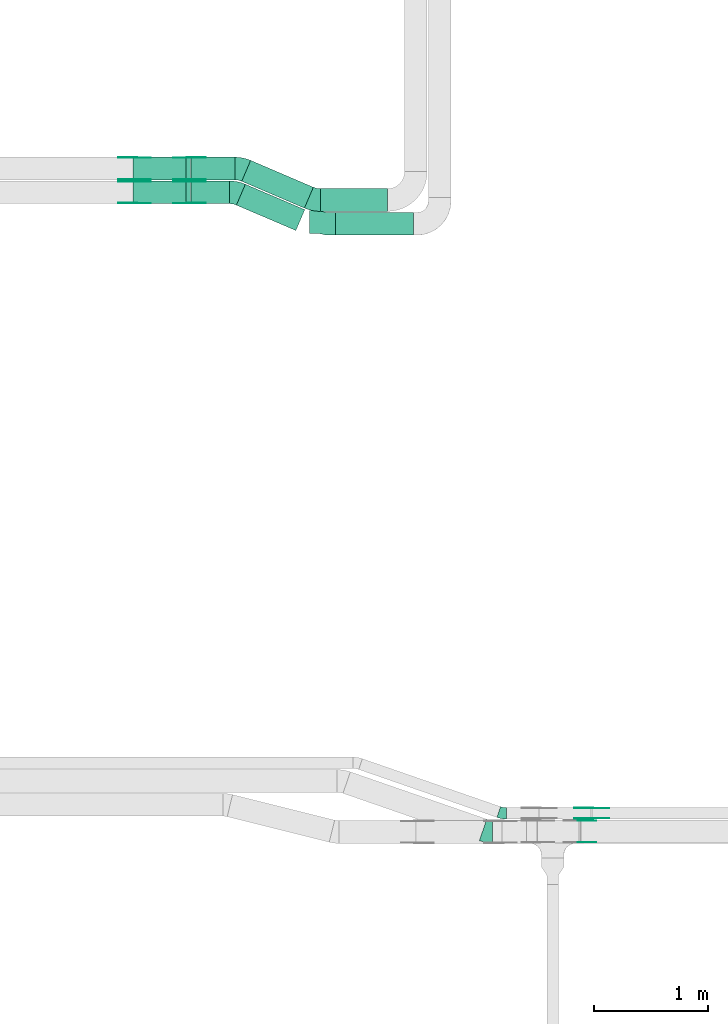
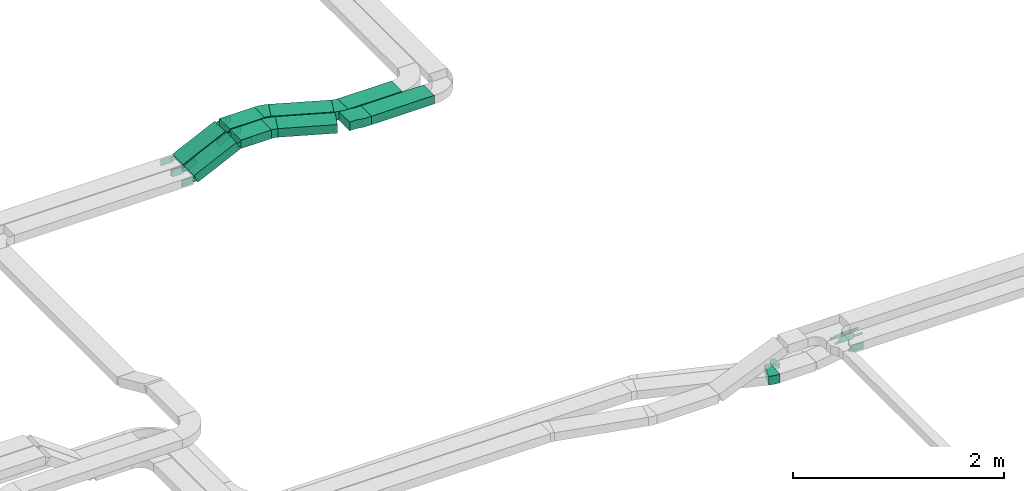
# One storey, part 15 of 25: 28 flow fittings, 8 flow segments.
"""IFC2X3 building model written with IfcOpenShell, lengths in millimetres."""

from ifc_helpers import new_model, entity, si_unit, converted_unit, derived_unit, direction, frame, frame_2d, origin, origin_2d_with_axis, place, context, subcontext, project, spatial, polyline, circle_curve, parameter, trimmed, segment, composite_curve, rectangle, outline, extrude, source, transform, mapped, material, type_object, type_shapes, element, save


model = new_model("IFC2X3")

# Units and contexts
model_context = context("Model", 3, precision=0.01, world=origin(), true_north=direction((6.12303176911189e-17, 1.0)))
body_context = subcontext(model_context, "Body", "Model", "MODEL_VIEW")
ifc_project = project(units=[si_unit("LENGTHUNIT", "METRE", prefix="MILLI"), si_unit("AREAUNIT", "SQUARE_METRE"), si_unit("VOLUMEUNIT", "CUBIC_METRE"), converted_unit("PLANEANGLEUNIT", "DEGREE", entity("IfcRatioMeasure", 0.0174532925199433), si_unit("PLANEANGLEUNIT", "RADIAN"), dimensions=[0, 0, 0, 0, 0, 0, 0]), si_unit("MASSUNIT", "GRAM", prefix="KILO"), derived_unit("MASSDENSITYUNIT", [(si_unit("MASSUNIT", "GRAM", prefix="KILO"), 1), (si_unit("LENGTHUNIT", "METRE"), -3)]), derived_unit("MOMENTOFINERTIAUNIT", [(si_unit("LENGTHUNIT", "METRE"), 4)]), si_unit("TIMEUNIT", "SECOND"), si_unit("FREQUENCYUNIT", "HERTZ"), si_unit("THERMODYNAMICTEMPERATUREUNIT", "DEGREE_CELSIUS"), derived_unit("THERMALTRANSMITTANCEUNIT", [(si_unit("MASSUNIT", "GRAM", prefix="KILO"), 1), (si_unit("THERMODYNAMICTEMPERATUREUNIT", "KELVIN"), -1), (si_unit("TIMEUNIT", "SECOND"), -3)]), derived_unit("VOLUMETRICFLOWRATEUNIT", [(si_unit("LENGTHUNIT", "METRE"), 3), (si_unit("TIMEUNIT", "SECOND"), -1)]), derived_unit("MASSFLOWRATEUNIT", [(si_unit("MASSUNIT", "GRAM", prefix="KILO"), 1), (si_unit("TIMEUNIT", "SECOND"), -1)]), derived_unit("ROTATIONALFREQUENCYUNIT", [(si_unit("TIMEUNIT", "SECOND"), -1)]), si_unit("ELECTRICCURRENTUNIT", "AMPERE"), si_unit("ELECTRICVOLTAGEUNIT", "VOLT"), si_unit("POWERUNIT", "WATT"), si_unit("FORCEUNIT", "NEWTON", prefix="KILO"), si_unit("ILLUMINANCEUNIT", "LUX"), si_unit("LUMINOUSFLUXUNIT", "LUMEN"), si_unit("LUMINOUSINTENSITYUNIT", "CANDELA"), derived_unit("USERDEFINED", [(si_unit("MASSUNIT", "GRAM", prefix="KILO"), -1), (si_unit("LENGTHUNIT", "METRE"), -2), (si_unit("TIMEUNIT", "SECOND"), 3), (si_unit("LUMINOUSFLUXUNIT", "LUMEN"), 1)]), derived_unit("LINEARVELOCITYUNIT", [(si_unit("LENGTHUNIT", "METRE"), 1), (si_unit("TIMEUNIT", "SECOND"), -1)]), si_unit("PRESSUREUNIT", "PASCAL"), derived_unit("USERDEFINED", [(si_unit("LENGTHUNIT", "METRE"), -2), (si_unit("MASSUNIT", "GRAM", prefix="KILO"), 1), (si_unit("TIMEUNIT", "SECOND"), -2)]), derived_unit("LINEARFORCEUNIT", [(si_unit("MASSUNIT", "GRAM", prefix="KILO"), 1), (si_unit("LENGTHUNIT", "METRE"), 1), (si_unit("TIMEUNIT", "SECOND"), -2), (si_unit("LENGTHUNIT", "METRE"), -1)]), derived_unit("PLANARFORCEUNIT", [(si_unit("MASSUNIT", "GRAM", prefix="KILO"), 1), (si_unit("LENGTHUNIT", "METRE"), 1), (si_unit("TIMEUNIT", "SECOND"), -2), (si_unit("LENGTHUNIT", "METRE"), -2)])], contexts=[model_context])

# Site, building, storey
site_placement = place(None, frame((0.0, -0.00077364408347762, 0.0)))
site = spatial("IfcSite", under=ifc_project, at=site_placement, CompositionType="ELEMENT")
building_placement = place(site_placement, origin())
building = spatial("IfcBuilding", under=site, at=building_placement, CompositionType="ELEMENT")
storey_placement = place(building_placement, frame((0.0, 0.0, 24000.0)))
storey = spatial("IfcBuildingStorey", under=building, at=storey_placement, CompositionType="ELEMENT", Elevation=24000.0)

# Flow segments
cable_carrier_segment_type = type_object("IfcCableCarrierSegmentType", PredefinedType="CABLETRAYSEGMENT")
flow_segment_1_placement = place(storey_placement, frame((39514.0995028436, 14090.3144759065, 2883.62105725889)))
element("IfcFlowSegment", 1, at=flow_segment_1_placement, inside=storey, type_object=cable_carrier_segment_type, context=body_context, shape_type="SweptSolid", body=[
    extrude(rectangle(XDim=686.50102542503, YDim=199.999999999998, at=frame_2d((-4.32009983342141e-12, 1.08002495835535e-12), x_axis=(1.0, 0.0))), frame((343.250512712511, 100.0, 0.0), z_axis=(0.0, 0.0, 1.0), x_axis=(-1.0, 0.0, 0.0)), (0.0, 0.0, 1.0), 100.000000000003),
])
flow_segment_2_placement = place(storey_placement, frame((39379.2280429504, 14300.3144759065, 2883.62105725893)))
element("IfcFlowSegment", 2, at=flow_segment_2_placement, inside=storey, type_object=cable_carrier_segment_type, context=body_context, shape_type="SweptSolid", body=[
    extrude(rectangle(XDim=590.372485318248, YDim=199.999999999998, at=frame_2d((0.0, 1.08002495835535e-12), x_axis=(1.0, 0.0))), frame((295.186242659133, 100.0, 0.0), z_axis=(0.0, 0.0, 1.0), x_axis=(-1.0, 0.0, 0.0)), (0.0, 0.0, 1.0), 100.000000000003),
])
flow_segment_3_placement = place(storey_placement, frame((38242.0489672401, 14367.8235638229, 2883.62105725891)))
element("IfcFlowSegment", 3, at=flow_segment_3_placement, inside=storey, type_object=cable_carrier_segment_type, context=body_context, shape_type="SweptSolid", body=[
    extrude(rectangle(XDim=337.638555069506, YDim=199.999999999998, at=origin_2d_with_axis()), frame((168.819277534753, 100.0, 0.0), z_axis=(0.0, 0.0, 1.0), x_axis=(-1.0, 0.0, 0.0)), (0.0, 0.0, 1.0), 100.000000000003),
])
flow_segment_4_placement = place(storey_placement, frame((38242.0489672412, 14577.8235638229, 2883.62105725665)))
element("IfcFlowSegment", 4, at=flow_segment_4_placement, inside=storey, type_object=cable_carrier_segment_type, context=body_context, shape_type="SweptSolid", body=[
    extrude(rectangle(XDim=384.036141225792, YDim=199.999999999998, at=origin_2d_with_axis()), frame((192.018070612896, 100.0, 0.0)), (0.0, 0.0, 1.0), 100.000000000003),
])
flow_segment_5_placement = place(storey_placement, frame((37730.9889069664, 14367.8235638229, 2660.62054262627)))
element("IfcFlowSegment", 5, at=flow_segment_5_placement, inside=storey, type_object=cable_carrier_segment_type, context=body_context, shape_type="SweptSolid", body=[
    extrude(rectangle(XDim=99.9999999999961, YDim=200.000000000002, at=origin_2d_with_axis()), frame((21.5836568252733, 100.0, 45.1015050530337), z_axis=(0.90203010106071, 0.0, 0.431673136505395), x_axis=(-0.431673136505395, 0.0, 0.90203010106071)), (0.0, 0.0, 1.0), 514.687950468755),
])
flow_segment_6_placement = place(storey_placement, frame((37730.9889069667, 14577.8235638229, 2660.62054262617)))
element("IfcFlowSegment", 6, at=flow_segment_6_placement, inside=storey, type_object=cable_carrier_segment_type, context=body_context, shape_type="SweptSolid", body=[
    extrude(rectangle(XDim=99.9999999999967, YDim=199.999999999998, at=origin_2d_with_axis()), frame((21.5836568250567, 100.0, 45.1015050531334), z_axis=(0.902030101062784, 0.0, 0.431673136501061), x_axis=(-0.431673136501061, 0.0, 0.902030101062784)), (0.0, 0.0, 1.0), 514.68795046868),
])
flow_segment_7_placement = place(storey_placement, frame((38640.6053688898, 14131.351704141, 2883.62105725891)))
element("IfcFlowSegment", 7, at=flow_segment_7_placement, inside=storey, type_object=cable_carrier_segment_type, context=body_context, shape_type="SweptSolid", body=[
    extrude(rectangle(XDim=569.477519390941, YDim=199.999999999997, at=frame_2d((-2.41584530158434e-12, 1.35003119794419e-13), x_axis=(1.0, 0.0))), frame((301.121218055428, 203.934332835351, 0.0), z_axis=(0.0, 0.0, 1.0), x_axis=(-0.919400368467263, 0.393322974745006, 0.0)), (0.0, 0.0, 1.0), 99.9999999999989),
])
flow_segment_8_placement = place(storey_placement, frame((38687.002955047, 14328.9176699176, 2883.62105725665)))
element("IfcFlowSegment", 8, at=flow_segment_8_placement, inside=storey, type_object=cable_carrier_segment_type, context=body_context, shape_type="SweptSolid", body=[
    extrude(rectangle(XDim=601.090303341187, YDim=199.999999999999, at=frame_2d((-2.38742359215394e-12, 1.49213974509621e-13), x_axis=(1.0, 0.0))), frame((315.653620661844, 210.151349946992, 1.1435076885391e-09), z_axis=(0.0, 0.0, 1.0), x_axis=(-0.919400368467261, 0.393322974745012, 0.0)), (0.0, 0.0, 1.0), 100.000000000003),
])

# Flow fittings
ifc_material_1 = material(Name="G")
cable_carrier_fitting_type_1 = type_object("IfcCableCarrierFittingType", PredefinedType="NOTDEFINED", material=ifc_material_1)
shared_shape_1 = source(origin(), body_context, "Body", "SweptSolid", [
    extrude(outline(composite_curve([segment(trimmed(circle_curve(frame_2d((-44.5901162790698, 0.0), x_axis=(1.0, 0.0)), 12.5), [parameter(90.0000000000007)], [parameter(270.0)], True, "PARAMETER"), True, "CONTINUOUS"), segment(polyline([(-44.5901162790697, -12.5), (-33.0901162790698, -12.5)]), True, "CONTINUOUS"), segment(polyline([(-33.0901162790698, -12.5), (-31.2296511627907, -14.5)]), True, "CONTINUOUS"), segment(polyline([(-31.2296511627907, -14.5), (108.90988372093, -14.5)]), True, "CONTINUOUS"), segment(polyline([(108.90988372093, -14.5), (108.90988372093, 14.5)]), True, "CONTINUOUS"), segment(polyline([(108.90988372093, 14.5), (-31.2296511627907, 14.5)]), True, "CONTINUOUS"), segment(polyline([(-31.2296511627907, 14.5), (-33.0901162790698, 12.5)]), True, "CONTINUOUS"), segment(polyline([(-33.0901162790698, 12.5), (-44.5901162790699, 12.5)]), True, "CONTINUOUS")], self_intersect=False)), frame((44.5901162790698, 0.0, 0.0), z_axis=(0.0, 0.0, -1.0), x_axis=(1.0, 0.0, 0.0)), (0.0, 0.0, -1.0), 2.0),
])
type_shapes(cable_carrier_fitting_type_1, [shared_shape_1])
flow_fitting_1_placement = place(storey_placement, frame((41768.9701607066, 8954.52925077039, 2745.0), z_axis=(0.0, -1.0, 0.0), x_axis=(-0.991697353687333, 0.0, -0.128593773914372)))
element("IfcFlowFitting", 9, at=flow_fitting_1_placement, inside=storey, type_object=cable_carrier_fitting_type_1, material=ifc_material_1, context=body_context, shape_type="MappedRepresentation", body=[
    mapped(shared_shape_1, transform((0.0, 0.0, 0.0), scale=1.0)),
])
cable_carrier_fitting_type_2 = type_object("IfcCableCarrierFittingType", PredefinedType="NOTDEFINED", material=ifc_material_1)
shared_shape_2 = source(origin(), body_context, "Body", "SweptSolid", [
    extrude(outline(composite_curve([segment(trimmed(circle_curve(frame_2d((-44.5901162790697, 0.0), x_axis=(1.0, 0.0)), 12.5), [parameter(90.0000000000007)], [parameter(270.0)], True, "PARAMETER"), True, "CONTINUOUS"), segment(polyline([(-44.5901162790697, -12.5), (-33.0901162790697, -12.5)]), True, "CONTINUOUS"), segment(polyline([(-33.0901162790697, -12.5), (-31.2296511627907, -14.5)]), True, "CONTINUOUS"), segment(polyline([(-31.2296511627907, -14.5), (108.90988372093, -14.5)]), True, "CONTINUOUS"), segment(polyline([(108.90988372093, -14.5), (108.90988372093, 14.5)]), True, "CONTINUOUS"), segment(polyline([(108.90988372093, 14.5), (-31.2296511627907, 14.5)]), True, "CONTINUOUS"), segment(polyline([(-31.2296511627907, 14.5), (-33.0901162790698, 12.5)]), True, "CONTINUOUS"), segment(polyline([(-33.0901162790698, 12.5), (-44.5901162790699, 12.5)]), True, "CONTINUOUS")], self_intersect=False)), frame((44.5901162790697, 0.0, 0.0)), (0.0, 0.0, 1.0), 2.0),
])
type_shapes(cable_carrier_fitting_type_2, [shared_shape_2])
flow_fitting_2_placement = place(storey_placement, frame((41768.9701607066, 9045.44925079071, 2745.0), z_axis=(0.0, 1.0, 0.0), x_axis=(-0.991697353687333, 0.0, -0.128593773914372)))
element("IfcFlowFitting", 10, at=flow_fitting_2_placement, inside=storey, type_object=cable_carrier_fitting_type_2, material=ifc_material_1, context=body_context, shape_type="MappedRepresentation", body=[
    mapped(shared_shape_2, transform((0.0, 0.0, 0.0), scale=1.0)),
])
cable_carrier_fitting_type_3 = type_object("IfcCableCarrierFittingType", PredefinedType="NOTDEFINED", material=ifc_material_1)
shared_shape_3 = source(origin(), body_context, "Body", "SweptSolid", [
    extrude(outline(composite_curve([segment(trimmed(circle_curve(frame_2d((-44.5901162790698, 0.0), x_axis=(1.0, 0.0)), 12.5), [parameter(90.0000000000007)], [parameter(270.0)], True, "PARAMETER"), True, "CONTINUOUS"), segment(polyline([(-44.5901162790697, -12.5), (-33.0901162790698, -12.5)]), True, "CONTINUOUS"), segment(polyline([(-33.0901162790698, -12.5), (-31.2296511627907, -14.5)]), True, "CONTINUOUS"), segment(polyline([(-31.2296511627907, -14.5), (108.90988372093, -14.5)]), True, "CONTINUOUS"), segment(polyline([(108.90988372093, -14.5), (108.90988372093, 14.5)]), True, "CONTINUOUS"), segment(polyline([(108.90988372093, 14.5), (-31.2296511627907, 14.5)]), True, "CONTINUOUS"), segment(polyline([(-31.2296511627907, 14.5), (-33.0901162790698, 12.5)]), True, "CONTINUOUS"), segment(polyline([(-33.0901162790698, 12.5), (-44.5901162790699, 12.5)]), True, "CONTINUOUS")], self_intersect=False)), frame((44.5901162790698, 0.0, 0.0), z_axis=(0.0, 0.0, -1.0), x_axis=(1.0, 0.0, 0.0)), (0.0, 0.0, -1.0), 2.0),
])
type_shapes(cable_carrier_fitting_type_3, [shared_shape_3])
flow_fitting_3_placement = place(storey_placement, frame((41768.9701607066, 9043.44925079071, 2745.0), z_axis=(0.0, 1.0, 0.0), x_axis=(1.0, 0.0, 0.0)))
element("IfcFlowFitting", 11, at=flow_fitting_3_placement, inside=storey, type_object=cable_carrier_fitting_type_3, material=ifc_material_1, context=body_context, shape_type="MappedRepresentation", body=[
    mapped(shared_shape_3, transform((0.0, 0.0, 0.0), scale=1.0)),
])
cable_carrier_fitting_type_4 = type_object("IfcCableCarrierFittingType", PredefinedType="NOTDEFINED", material=ifc_material_1)
shared_shape_4 = source(origin(), body_context, "Body", "SweptSolid", [
    extrude(outline(composite_curve([segment(trimmed(circle_curve(frame_2d((-44.5901162790697, 0.0), x_axis=(1.0, 0.0)), 12.5), [parameter(90.0000000000007)], [parameter(270.0)], True, "PARAMETER"), True, "CONTINUOUS"), segment(polyline([(-44.5901162790697, -12.5), (-33.0901162790697, -12.5)]), True, "CONTINUOUS"), segment(polyline([(-33.0901162790697, -12.5), (-31.2296511627907, -14.5)]), True, "CONTINUOUS"), segment(polyline([(-31.2296511627907, -14.5), (108.90988372093, -14.5)]), True, "CONTINUOUS"), segment(polyline([(108.90988372093, -14.5), (108.90988372093, 14.5)]), True, "CONTINUOUS"), segment(polyline([(108.90988372093, 14.5), (-31.2296511627907, 14.5)]), True, "CONTINUOUS"), segment(polyline([(-31.2296511627907, 14.5), (-33.0901162790698, 12.5)]), True, "CONTINUOUS"), segment(polyline([(-33.0901162790698, 12.5), (-44.5901162790699, 12.5)]), True, "CONTINUOUS")], self_intersect=False)), frame((44.5901162790697, 0.0, 0.0)), (0.0, 0.0, 1.0), 2.0),
])
type_shapes(cable_carrier_fitting_type_4, [shared_shape_4])
flow_fitting_4_placement = place(storey_placement, frame((41768.9701607066, 8956.5292507704, 2745.0), z_axis=(0.0, -1.0, 0.0), x_axis=(1.0, 0.0, 0.0)))
element("IfcFlowFitting", 12, at=flow_fitting_4_placement, inside=storey, type_object=cable_carrier_fitting_type_4, material=ifc_material_1, context=body_context, shape_type="MappedRepresentation", body=[
    mapped(shared_shape_4, transform((0.0, 0.0, 0.0), scale=1.0)),
])
cable_carrier_fitting_type_5 = type_object("IfcCableCarrierFittingType", PredefinedType="NOTDEFINED", material=ifc_material_1)
shared_shape_5 = source(origin(), body_context, "Body", "SweptSolid", [
    extrude(outline(composite_curve([segment(trimmed(circle_curve(frame_2d((-41.4651162790697, 0.0), x_axis=(1.0, 0.0)), 25.0), [parameter(90.0000000000007)], [parameter(270.0)], True, "PARAMETER"), True, "CONTINUOUS"), segment(polyline([(-41.4651162790697, -25.0), (-29.9651162790697, -25.0)]), True, "CONTINUOUS"), segment(polyline([(-29.9651162790697, -25.0), (-28.1046511627907, -38.5)]), True, "CONTINUOUS"), segment(polyline([(-28.1046511627907, -38.5), (99.5348837209303, -38.5)]), True, "CONTINUOUS"), segment(polyline([(99.5348837209303, -38.5), (99.5348837209303, 38.5)]), True, "CONTINUOUS"), segment(polyline([(99.5348837209303, 38.5), (-28.1046511627907, 38.5)]), True, "CONTINUOUS"), segment(polyline([(-28.1046511627907, 38.5), (-29.9651162790697, 25.0)]), True, "CONTINUOUS"), segment(polyline([(-29.9651162790697, 25.0), (-41.46511627907, 25.0)]), True, "CONTINUOUS")], self_intersect=False)), frame((41.4651162790697, 0.0, 0.0), z_axis=(0.0, 0.0, -1.0), x_axis=(1.0, 0.0, 0.0)), (0.0, 0.0, -1.0), 2.0),
])
type_shapes(cable_carrier_fitting_type_5, [shared_shape_5])
for number, where, z_axis, x_axis in (
    (13, (38228.7934570049, 14372.3635638127, 2933.62105725892), (0.0, -1.0, 0.0), (-0.902030101060717, 0.0, -0.43167313650538)),
    (14, (37740.6156945546, 14372.3635638127, 2700.0), (0.0, -1.0, 0.0), (0.902030101060717, 0.0, 0.43167313650538)),
    (15, (38228.793457006, 14773.283563833, 2933.62105725666), (0.0, 1.0, 0.0), (1.0, 0.0, 0.0)),
    (16, (37740.6156945545, 14773.283563833, 2700.0), (0.0, 1.0, 0.0), (-1.0, 0.0, 0.0)),
):
    element("IfcFlowFitting", number, at=place(storey_placement, frame(where, z_axis=z_axis, x_axis=x_axis)), inside=storey, type_object=cable_carrier_fitting_type_5, material=ifc_material_1, context=body_context, shape_type="MappedRepresentation", body=[
        mapped(shared_shape_5, transform((0.0, 0.0, 0.0), scale=1.0)),
    ])
cable_carrier_fitting_type_6 = type_object("IfcCableCarrierFittingType", PredefinedType="NOTDEFINED", material=ifc_material_1)
shared_shape_6 = source(origin(), body_context, "Body", "SweptSolid", [
    extrude(outline(composite_curve([segment(trimmed(circle_curve(frame_2d((-41.4651162790697, 0.0), x_axis=(1.0, 0.0)), 25.0), [parameter(90.0000000000007)], [parameter(270.0)], True, "PARAMETER"), True, "CONTINUOUS"), segment(polyline([(-41.4651162790697, -25.0), (-29.9651162790697, -25.0)]), True, "CONTINUOUS"), segment(polyline([(-29.9651162790697, -25.0), (-28.1046511627907, -38.5)]), True, "CONTINUOUS"), segment(polyline([(-28.1046511627907, -38.5), (99.5348837209303, -38.5)]), True, "CONTINUOUS"), segment(polyline([(99.5348837209303, -38.5), (99.5348837209303, 38.5)]), True, "CONTINUOUS"), segment(polyline([(99.5348837209303, 38.5), (-28.1046511627907, 38.5)]), True, "CONTINUOUS"), segment(polyline([(-28.1046511627907, 38.5), (-29.9651162790697, 25.0)]), True, "CONTINUOUS"), segment(polyline([(-29.9651162790697, 25.0), (-41.46511627907, 25.0)]), True, "CONTINUOUS")], self_intersect=False)), frame((41.4651162790697, 0.0, 0.0)), (0.0, 0.0, 1.0), 2.0),
])
type_shapes(cable_carrier_fitting_type_6, [shared_shape_6])
for number, where, z_axis, x_axis in (
    (17, (38228.7934570049, 14563.2835638331, 2933.62105725892), (0.0, 1.0, 0.0), (-0.902030101060717, 0.0, -0.43167313650538)),
    (18, (37740.6156945546, 14563.2835638331, 2700.0), (0.0, 1.0, 0.0), (0.902030101060717, 0.0, 0.43167313650538)),
    (19, (38228.793457006, 14582.3635638127, 2933.62105725666), (0.0, -1.0, 0.0), (1.0, 0.0, 0.0)),
    (20, (37740.6156945545, 14582.3635638127, 2700.0), (0.0, -1.0, 0.0), (-1.0, 0.0, 0.0)),
):
    element("IfcFlowFitting", number, at=place(storey_placement, frame(where, z_axis=z_axis, x_axis=x_axis)), inside=storey, type_object=cable_carrier_fitting_type_6, material=ifc_material_1, context=body_context, shape_type="MappedRepresentation", body=[
        mapped(shared_shape_6, transform((0.0, 0.0, 0.0), scale=1.0)),
    ])
cable_carrier_fitting_type_7 = type_object("IfcCableCarrierFittingType", PredefinedType="NOTDEFINED", material=ifc_material_1)
shared_shape_7 = source(origin(), body_context, "Body", "SweptSolid", [
    extrude(outline(composite_curve([segment(trimmed(circle_curve(frame_2d((-41.4651162790697, 0.0), x_axis=(1.0, 0.0)), 25.0), [parameter(90.0000000000007)], [parameter(270.0)], True, "PARAMETER"), True, "CONTINUOUS"), segment(polyline([(-41.4651162790697, -25.0), (-29.9651162790697, -25.0)]), True, "CONTINUOUS"), segment(polyline([(-29.9651162790697, -25.0), (-28.1046511627907, -38.5)]), True, "CONTINUOUS"), segment(polyline([(-28.1046511627907, -38.5), (99.5348837209303, -38.5)]), True, "CONTINUOUS"), segment(polyline([(99.5348837209303, -38.5), (99.5348837209303, 38.5)]), True, "CONTINUOUS"), segment(polyline([(99.5348837209303, 38.5), (-28.1046511627907, 38.5)]), True, "CONTINUOUS"), segment(polyline([(-28.1046511627907, 38.5), (-29.9651162790697, 25.0)]), True, "CONTINUOUS"), segment(polyline([(-29.9651162790697, 25.0), (-41.46511627907, 25.0)]), True, "CONTINUOUS")], self_intersect=False)), frame((41.4651162790697, 0.0, 0.0), z_axis=(0.0, 0.0, -1.0), x_axis=(1.0, 0.0, 0.0)), (0.0, 0.0, -1.0), 2.0),
])
type_shapes(cable_carrier_fitting_type_7, [shared_shape_7])
for number, where, z_axis, x_axis in (
    (21, (38228.7934570049, 14561.2835638331, 2933.62105725892), (0.0, 1.0, 0.0), (1.0, 0.0, 0.0)),
    (22, (37740.6156945546, 14561.2835638331, 2700.0), (0.0, 1.0, 0.0), (-1.0, 0.0, 0.0)),
    (23, (38228.793457006, 14584.3635638127, 2933.62105725666), (0.0, -1.0, 0.0), (-0.90203010106066, 0.0, -0.431673136505499)),
    (24, (41668.9701607069, 8933.44925079089, 2770.0), (0.0, 1.0, 0.0), (1.0, 0.0, 0.0)),
    (25, (37740.6156945545, 14584.3635638127, 2700.0), (0.0, -1.0, 0.0), (0.902030101062787, 0.0, 0.431673136501055)),
):
    element("IfcFlowFitting", number, at=place(storey_placement, frame(where, z_axis=z_axis, x_axis=x_axis)), inside=storey, type_object=cable_carrier_fitting_type_7, material=ifc_material_1, context=body_context, shape_type="MappedRepresentation", body=[
        mapped(shared_shape_7, transform((0.0, 0.0, 0.0), scale=1.0)),
    ])
cable_carrier_fitting_type_8 = type_object("IfcCableCarrierFittingType", PredefinedType="NOTDEFINED", material=ifc_material_1)
shared_shape_8 = source(origin(), body_context, "Body", "SweptSolid", [
    extrude(outline(composite_curve([segment(trimmed(circle_curve(frame_2d((-41.4651162790697, 0.0), x_axis=(1.0, 0.0)), 25.0), [parameter(90.0000000000007)], [parameter(270.0)], True, "PARAMETER"), True, "CONTINUOUS"), segment(polyline([(-41.4651162790697, -25.0), (-29.9651162790697, -25.0)]), True, "CONTINUOUS"), segment(polyline([(-29.9651162790697, -25.0), (-28.1046511627907, -38.5)]), True, "CONTINUOUS"), segment(polyline([(-28.1046511627907, -38.5), (99.5348837209303, -38.5)]), True, "CONTINUOUS"), segment(polyline([(99.5348837209303, -38.5), (99.5348837209303, 38.5)]), True, "CONTINUOUS"), segment(polyline([(99.5348837209303, 38.5), (-28.1046511627907, 38.5)]), True, "CONTINUOUS"), segment(polyline([(-28.1046511627907, 38.5), (-29.9651162790697, 25.0)]), True, "CONTINUOUS"), segment(polyline([(-29.9651162790697, 25.0), (-41.46511627907, 25.0)]), True, "CONTINUOUS")], self_intersect=False)), frame((41.4651162790697, 0.0, 0.0)), (0.0, 0.0, 1.0), 2.0),
])
type_shapes(cable_carrier_fitting_type_8, [shared_shape_8])
for number, where, z_axis, x_axis in (
    (26, (38228.7934570049, 14374.3635638127, 2933.62105725891), (0.0, -1.0, 0.0), (1.0, 0.0, 0.0)),
    (27, (37740.6156945546, 14374.3635638127, 2700.0), (0.0, -1.0, 0.0), (-1.0, 0.0, 0.0)),
    (28, (38228.793457006, 14771.283563833, 2933.62105725666), (0.0, 1.0, 0.0), (-0.90203010106066, 0.0, -0.431673136505499)),
    (29, (41668.9701607069, 8746.52925077057, 2770.0), (0.0, -1.0, 0.0), (1.0, 0.0, 0.0)),
    (30, (37740.6156945545, 14771.283563833, 2700.0), (0.0, 1.0, 0.0), (0.902030101062787, 0.0, 0.431673136501055)),
):
    element("IfcFlowFitting", number, at=place(storey_placement, frame(where, z_axis=z_axis, x_axis=x_axis)), inside=storey, type_object=cable_carrier_fitting_type_8, material=ifc_material_1, context=body_context, shape_type="MappedRepresentation", body=[
        mapped(shared_shape_8, transform((0.0, 0.0, 0.0), scale=1.0)),
    ])
ifc_material_2 = material()
cable_carrier_fitting_type_9 = type_object("IfcCableCarrierFittingType", Name="470_DKC_S5_Variable Angle Elbow 0-45:-", PredefinedType="NOTDEFINED", material=ifc_material_2)
shared_shape_9 = source(origin(), body_context, "Body", "SweptSolid", [
    extrude(outline(composite_curve([segment(polyline([(-50.1452219352397, -110.173284685277), (-49.1452219352383, -110.173284685277)]), True, "CONTINUOUS"), segment(trimmed(circle_curve(frame_2d((-49.1452219352389, 239.826715314723), x_axis=(0.0, -1.0)), 350.0), [parameter(0.0)], [parameter(23.1614232641994)], True, "PARAMETER"), True, "CONTINUOUS"), segment(polyline([(88.5178192255027, -81.9634136488233), (89.4372195939699, -81.5700906740784)]), True, "CONTINUOUS"), segment(polyline([(89.4372195939699, -81.5700906740784), (10.7726246449749, 102.309983019377)]), True, "CONTINUOUS"), segment(polyline([(10.7726246449749, 102.309983019377), (9.85322427650746, 101.916660044632)]), True, "CONTINUOUS"), segment(trimmed(circle_curve(frame_2d((-49.1452219352389, 239.826715314723), x_axis=(0.0, -1.0)), 150.0), [parameter(0.0)], [parameter(23.1614232641994)], True, "PARAMETER"), False, "CONTINUOUS"), segment(polyline([(-49.1452219352383, 89.8267153147231), (-50.1452219352397, 89.8267153147231)]), True, "CONTINUOUS"), segment(polyline([(-50.1452219352397, 89.8267153147231), (-50.1452219352397, -110.173284685277)]), True, "CONTINUOUS")], self_intersect=False)), frame((-2.08470658912967, 10.1732846852687, -50.0)), (0.0, 0.0, 1.0), 100.0),
])
type_shapes(cable_carrier_fitting_type_9, [shared_shape_9])
for number, where, z_axis, x_axis, name in (
    (31, (38631.917450834, 14467.8235638229, 2933.62105725891), (0.0, 0.0, 1.0), (-0.91940036846727, 0.393322974744991, 0.0), "470_DKC_S5_Variable Angle Elbow 0-45:-"),
    (32, (39326.998114426, 14400.3144759065, 2933.62105725893), (0.0, 0.0, 1.0), (0.91940036846726, -0.393322974745013, 0.0), "470_DKC_S5_Variable Angle Elbow 0-45:-"),
    (33, (38678.3150369914, 14677.8235638229, 2933.62105725665), (0.0, 0.0, 1.0), (-0.919400368467258, 0.393322974745018, 0.0), "470_DKC_S5_Variable Angle Elbow 0-45:-"),
):
    element("IfcFlowFitting", number, at=place(storey_placement, frame(where, z_axis=z_axis, x_axis=x_axis)), inside=storey, type_object=cable_carrier_fitting_type_9, material=ifc_material_2, Name=name, ObjectType="470_DKC_S5_Variable Angle Elbow 0-45:-", context=body_context, shape_type="MappedRepresentation", body=[
        mapped(shared_shape_9, transform((0.0, 0.0, 0.0), scale=1.0)),
    ])
cable_carrier_fitting_type_10 = type_object("IfcCableCarrierFittingType", Name="470_DKC_S5_Variable Angle Elbow 0-45:-", PredefinedType="NOTDEFINED", material=ifc_material_2)
shared_shape_10 = source(origin(), body_context, "Body", "SweptSolid", [
    extrude(outline(composite_curve([segment(polyline([(-41.9646328661209, -106.989760877664), (-40.9646328661195, -106.989760877664)]), True, "CONTINUOUS"), segment(trimmed(circle_curve(frame_2d((-40.9646328661201, 243.010239122336), x_axis=(0.0, -1.0)), 350.0), [parameter(0.0)], [parameter(19.136971841609)], True, "PARAMETER"), True, "CONTINUOUS"), segment(polyline([(73.775022861308, -87.6479097316597), (74.7197604294621, -87.3200821438672)]), True, "CONTINUOUS"), segment(polyline([(74.7197604294621, -87.3200821438672), (9.1542428709321, 101.627431486988)]), True, "CONTINUOUS"), segment(polyline([(9.1542428709321, 101.627431486988), (8.20950530277761, 101.299603899195)]), True, "CONTINUOUS"), segment(trimmed(circle_curve(frame_2d((-40.9646328661201, 243.010239122336), x_axis=(0.0, -1.0)), 150.0), [parameter(0.0)], [parameter(19.136971841609)], True, "PARAMETER"), False, "CONTINUOUS"), segment(polyline([(-40.9646328661195, 93.0102391223359), (-41.9646328661209, 93.0102391223359)]), True, "CONTINUOUS"), segment(polyline([(-41.9646328661209, 93.0102391223359), (-41.9646328661209, -106.989760877664)]), True, "CONTINUOUS")], self_intersect=False)), frame((-1.17827540603723, 6.98976087765586, -50.0)), (0.0, 0.0, 1.0), 100.0),
])
type_shapes(cable_carrier_fitting_type_10, [shared_shape_10])
flow_fitting_5_placement = place(storey_placement, frame((40853.0827924389, 8839.98925078065, 2710.0), z_axis=(0.0, 0.0, 1.0), x_axis=(0.944737568154264, -0.327827587792681, 0.0)))
element("IfcFlowFitting", 34, at=flow_fitting_5_placement, inside=storey, type_object=cable_carrier_fitting_type_10, material=ifc_material_2, Name="470_DKC_S5_Variable Angle Elbow 0-45:-", ObjectType="470_DKC_S5_Variable Angle Elbow 0-45:-", context=body_context, shape_type="MappedRepresentation", body=[
    mapped(shared_shape_10, transform((0.0, 0.0, 0.0), scale=1.0)),
])
cable_carrier_fitting_type_11 = type_object("IfcCableCarrierFittingType", Name="470_DKC_S5_Variable Angle Elbow 0-45:-", PredefinedType="NOTDEFINED", material=ifc_material_2)
shared_shape_11 = source(origin(), body_context, "Body", "SweptSolid", [
    extrude(outline(composite_curve([segment(polyline([(-33.7689431713065, -55.6082000815214), (-32.7689431713052, -55.6082000815214)]), True, "CONTINUOUS"), segment(trimmed(circle_curve(frame_2d((-32.7689431713056, 194.391799918478), x_axis=(0.0, -1.0)), 250.0), [parameter(0.0)], [parameter(19.1369718416102)], True, "PARAMETER"), True, "CONTINUOUS"), segment(polyline([(49.187953776862, -41.7925921200882), (50.132691345016, -41.4647645322956)]), True, "CONTINUOUS"), segment(polyline([(50.132691345016, -41.4647645322956), (17.3499325657494, 53.0089922831311)]), True, "CONTINUOUS"), segment(polyline([(17.3499325657494, 53.0089922831311), (16.4051949975949, 52.6811646953384)]), True, "CONTINUOUS"), segment(trimmed(circle_curve(frame_2d((-32.7689431713056, 194.391799918478), x_axis=(0.0, -1.0)), 150.0), [parameter(0.0)], [parameter(19.1369718416102)], True, "PARAMETER"), False, "CONTINUOUS"), segment(polyline([(-32.7689431713052, 44.3917999184785), (-33.7689431713065, 44.3917999184785)]), True, "CONTINUOUS"), segment(polyline([(-33.7689431713065, 44.3917999184785), (-33.7689431713065, -55.6082000815214)]), True, "CONTINUOUS")], self_intersect=False)), frame((-0.945383446420344, 5.60820008151336, -25.0)), (0.0, 0.0, 1.0), 50.0000000000001),
])
type_shapes(cable_carrier_fitting_type_11, [shared_shape_11])
flow_fitting_6_placement = place(storey_placement, frame((40983.0827924361, 8999.98925078055, 2685.0), z_axis=(0.0, 0.0, 1.0), x_axis=(0.944737568154258, -0.327827587792697, 0.0)))
element("IfcFlowFitting", 35, at=flow_fitting_6_placement, inside=storey, type_object=cable_carrier_fitting_type_11, material=ifc_material_2, Name="470_DKC_S5_Variable Angle Elbow 0-45:-", ObjectType="470_DKC_S5_Variable Angle Elbow 0-45:-", context=body_context, shape_type="MappedRepresentation", body=[
    mapped(shared_shape_11, transform((0.0, 0.0, 0.0), scale=1.0)),
])
cable_carrier_fitting_type_12 = type_object("IfcCableCarrierFittingType", PredefinedType="NOTDEFINED", material=ifc_material_2)
shared_shape_12 = source(origin(), body_context, "Body", "SweptSolid", [
    extrude(outline(polyline([(-115.0, 91.7679921000439), (-115.0, -108.232007899956), (-38.3333333333284, -108.232007899956), (38.3333333333382, -91.7679921000409), (115.0, -91.767992100045), (115.0, 108.232007899955), (38.3333333333252, 108.232007899955), (-38.3333333333284, 91.7679921000439), (-115.0, 91.7679921000439)])), frame((115.0, -8.2320078999641, -50.0), z_axis=(0.0, 0.0, -1.0), x_axis=(1.0, 0.0, 0.0)), (0.0, 0.0, -1.0), 100.0),
])
type_shapes(cable_carrier_fitting_type_12, [shared_shape_12])
flow_fitting_7_placement = place(storey_placement, frame((39514.0995028436, 14190.3144759065, 2933.62105725893), z_axis=(0.0, 0.0, 1.0), x_axis=(-1.0, 0.0, 0.0)))
element("IfcFlowFitting", 36, at=flow_fitting_7_placement, inside=storey, type_object=cable_carrier_fitting_type_12, material=ifc_material_2, Name="470_DKC_S5_adapter", context=body_context, shape_type="MappedRepresentation", body=[
    mapped(shared_shape_12, transform((0.0, 0.0, 0.0), scale=1.0)),
])

save(model, "model.ifc")
